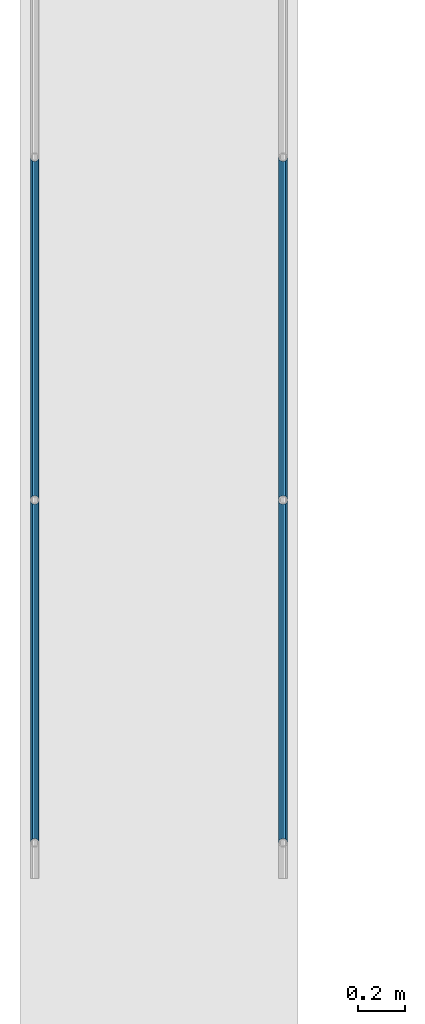
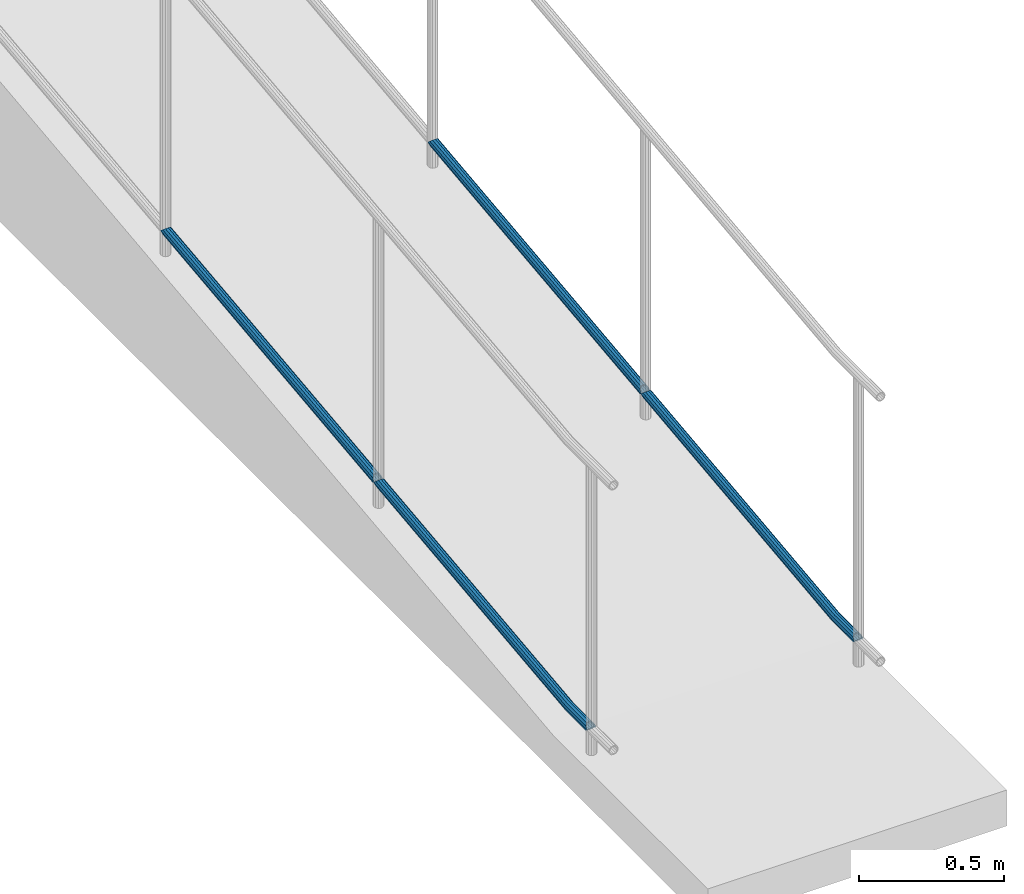
# One storey, part 1031 of 1763: 4 beams, 2 elements without a shape of their own.
"""IFC2X3 building model written with IfcOpenShell, lengths in millimetres."""

from ifc_helpers import new_model, si_unit, frame, origin_with_axes, place, context, subcontext, project, spatial, faceted_brep, material, type_object, element, aggregate, save


model = new_model("IFC2X3")

# Units and contexts
model_context = context("Model", 3, precision=1e-05, world=origin_with_axes())
body_context = subcontext(model_context, "Body", "Model", "MODEL_VIEW")
ifc_project = project(units=[si_unit("LENGTHUNIT", "METRE", prefix="MILLI"), si_unit("AREAUNIT", "SQUARE_METRE"), si_unit("VOLUMEUNIT", "CUBIC_METRE"), si_unit("MASSUNIT", "GRAM", prefix="KILO"), si_unit("TIMEUNIT", "SECOND"), si_unit("PLANEANGLEUNIT", "RADIAN"), si_unit("SOLIDANGLEUNIT", "STERADIAN"), si_unit("THERMODYNAMICTEMPERATUREUNIT", "DEGREE_CELSIUS"), si_unit("LUMINOUSINTENSITYUNIT", "LUMEN")], contexts=[model_context])

# Site, building, storey
site_placement = place(None, origin_with_axes())
site = spatial("IfcSite", under=ifc_project, at=site_placement, CompositionType="ELEMENT")
building_placement = place(site_placement, origin_with_axes())
building = spatial("IfcBuilding", under=site, at=building_placement, Name="Undefined", CompositionType="ELEMENT")
storey_placement = place(building_placement, origin_with_axes())
storey = spatial("IfcBuildingStorey", under=building, at=storey_placement, Name="Undefined", CompositionType="ELEMENT", Elevation=0.0)

# Assembly, beams
assembly_1_placement = place(storey_placement, origin_with_axes())
assembly_1 = element("IfcElementAssembly", 1, at=assembly_1_placement, inside=storey, Name="GUARDRAIL", AssemblyPlace="NOTDEFINED", PredefinedType="RIGID_FRAME")
ifc_material = material(Name="STEEL/A513")
beam_type = type_object("IfcBeamType", PredefinedType="NOTDEFINED")
beam_1_placement = place(assembly_1_placement, frame((-97200.6527017878, -12782.762133617, 3815.58511482554), z_axis=(0.0, -0.114062593029902, 0.993473565260443), x_axis=(0.0, -0.993473565260443, -0.114062593029902)))
beam_1 = element("IfcBeam", 2, at=beam_1_placement, type_object=beam_type, material=ifc_material, Name="GUARDRAIL", context=body_context, shape_type="Brep", body=[
    faceted_brep([(1480.81345318271, 19.0500000000029, 17.3825002176645), (1470.33122847514, 16.4977839420899, 25.7666268186786), (1472.5042094635, 16.4977839420899, 6.84096557126941), (1462.48219982441, -7.68349999999919, 28.6735604524383), (1460.20200757818, 0.0, 30.4840879673138), (1459.78189792043, 0.0, 34.1430491418123), (1462.60858252325, -9.52499999999418, 31.8985935448673), (1463.18246298811, -9.52499999999418, 26.9003596290404), (1463.18246298811, 9.52499999999418, 26.9003596290404), (1462.60858252325, 9.52499999999418, 31.8985935448673), (1462.48219982441, 7.68349999999919, 28.6735604524383), (1467.37252681534, 13.3082123799541, 23.5733481190482), (1470.29431449819, 15.3669999999984, 16.1748205455351), (1469.12539814594, 13.3082123799541, 8.30664804613843), (1465.79841553411, 9.52499999999418, 4.11662061334391), (1466.37229599897, 9.52499999999418, -0.881613302482037), (1465.51826202814, 7.68349999999919, 2.23086026224246), (1463.70775023939, 0.0, -0.0493121785057156), (1464.12785989714, 0.0, -3.70827335300419), (1465.51826202814, -7.68349999999919, 2.23086026224246), (1465.79841553411, -9.52499999999418, 4.11662061334391), (1466.37229599897, -9.52499999999418, -0.881613302482037), (1480.88055896293, -19.0500000000029, 17.39020507842), (1472.5042094635, -16.4977839420899, 6.84096557126941), (1470.33122847514, -16.4977839420899, 25.7666268186786), (1469.12539814594, -13.3082123799541, 8.30664804613843), (1470.29431449818, -15.3669999999984, 16.1748205455351), (1467.37252681534, -13.3082123799541, 23.5733481190482), (1327.81826570677, 9.52499999999418, 16.4977764218675), (1327.81826572123, 0.0, 19.0499924797741), (1328.31826572123, 0.0, 19.049992476942), (1328.46429331386, 9.52499999999418, 16.4977764182086), (1328.81500273226, 0.0, 19.107021784057), (1329.10610495904, 9.52499999999418, 16.5714614318267), (1328.46429331386, -9.52499999999418, 16.4977764182086), (1328.86324811624, -16.4977839420899, 9.5249924738564), (1329.9014110328, -16.4977839420899, 9.64418172387741), (1329.10610495904, -9.52499999999418, 16.5714614318267), (1327.81826570677, -9.52499999999418, 16.4977764218675), (1327.81826566729, -16.4977839420899, 9.52499247977448), (1327.81826561334, -19.0500000000029, -7.52022606320679e-06), (1329.40823051126, -19.0500000000029, -7.52923097024905e-06), (1330.98781933333, -19.0500000000029, 0.181341663697822), (16.9872402594065, 0.0, 19.0499999037911), (14.7112934167653, -9.52499999999418, 16.4977838587747), (8.49329100734212, -16.4977839420899, 9.52499995189828), (-0.000653948576655239, -19.0500000000029, 0.0), (10.6805481559259, -16.4977839420899, -9.52500006049013), (1327.8182655594, -16.4977839420899, -9.5250075202257), (1329.95321290627, -16.4977839420899, -9.52500753231743), (1332.07422763386, -16.4977839420899, -9.28149839648177), (1330.35216770865, -9.52499999999418, -16.4977914766696), (1332.86953370762, -9.52499999999418, -16.208778104432), (1327.81826551992, -9.52499999999418, -16.4977914623196), (1327.81826550547, 0.0, -19.0500075202253), (1330.49819530128, 0.0, -19.0500075354039), (1333.1606359344, 0.0, -18.7443384566614), (1330.35216770865, 9.52499999999418, -16.4977914766696), (1332.86953370762, 9.52499999999418, -16.208778104432), (1327.81826551992, 9.52499999999418, -16.4977914623196), (1327.8182655594, 16.4977839420899, -9.5250075202257), (1329.95321290627, 16.4977839420899, -9.52500753231652), (1332.07422763386, 16.4977839420899, -9.28149839648177), (1329.40823051126, 19.0500000000029, -7.52923097024905e-06), (1330.98781933333, 19.0500000000029, 0.181341663697822), (1327.81826561334, 19.0500000000029, -7.52022606320679e-06), (1327.81826566729, 16.4977839420899, 9.52499247977448), (1328.86324811624, 16.4977839420899, 9.5249924738564), (1329.9014110328, 16.4977839420899, 9.64418172387741), (8.49329100734212, 16.4977839420899, 9.52499995189828), (14.7112934167653, 9.52499999999418, 16.4977838587747), (1327.81826552632, 0.0, -15.3670075202253), (1327.81826553798, 7.68349999999919, -13.308219900181), (18.630188200199, 7.68349999999919, -13.3082124854682), (20.9388848411836, 0.0, -15.3670001185892), (1327.81826556984, 13.3082123799541, -7.68350752022525), (13.6796398687475, 13.3082123799541, -7.6835000774754), (17.9220831536149, 9.52499999999418, -11.4667124814578), (1327.81826561334, 15.3669999999984, -7.52022606320679e-06), (10.7251326051592, 15.3669999999984, -6.07424226473086e-08), (1327.81826565686, 13.3082123799541, 7.68349247977403), (11.9152524355613, 13.3082123799541, 7.68349993251741), (1327.81826570037, 0.0, 15.3669924797741), (1327.81826568871, -7.68349999999919, 13.3082048597298), (15.5741795216873, -7.68349999999919, 13.3082122917494), (17.4101099748004, 0.0, 15.3669999013964), (1327.81826568871, 7.68349999999919, 13.3082048597298), (15.5741795216891, 7.68349999999919, 13.3082122917494), (15.2889441904827, 9.52499999999418, 11.4667122933661), (15.2889441904827, -9.52499999999418, 11.4667122933661), (1327.81826565686, -13.3082123799541, 7.68349247977403), (11.9152524355613, -13.3082123799541, 7.68349993251741), (1327.81826561334, -15.3669999999984, -7.52022606320679e-06), (10.7251326051592, -15.3669999999984, -6.07415131526068e-08), (1327.81826556984, -13.3082123799541, -7.68350752022525), (13.6796398687475, -13.3082123799541, -7.68350007747449), (1327.81826553798, -7.68349999999919, -13.308219900181), (18.6301882001972, -7.68349999999919, -13.3082124854691), (17.9220831536149, -9.52499999999418, -11.4667124814578), (18.4997339273341, -9.52499999999418, -16.4977840468673), (21.3617545565776, 0.0, -19.0500001209839), (18.4997339273341, 9.52499999999418, -16.4977840468673), (10.6805481559259, 16.4977839420899, -9.52500006049013), (-0.000653948576655239, 19.0500000000029, 0.0), (1330.16967318382, -7.68349999999919, -13.3082199134988), (1330.28746877521, 0.0, -15.3670075342097), (1330.16967318382, 7.68349999999919, -13.3082199134988), (1329.84784964324, 13.3082123799541, -7.68350753172035), (1329.40823051126, 15.3669999999984, -7.52923097024905e-06), (1328.96861137928, 13.3082123799541, 7.68349247325932), (1328.64678783869, 7.68349999999919, 13.3082048550368), (1328.5289922473, 0.0, 15.3669924757487), (1328.64678783869, -7.68349999999919, 13.3082048550368), (1328.96861137928, -13.3082123799541, 7.68349247325932), (1329.40823051126, -15.3669999999984, -7.52923097024905e-06), (1329.84784964324, -13.3082123799541, -7.68350753172035), (1331.86418869576, -13.3082123799541, -7.45201598484709), (1332.50573559526, -7.68349999999919, -13.0400216159269), (1332.74055805819, 0.0, -15.085373633392), (1332.50573559526, 7.68349999999919, -13.0400216159269), (1331.86418869576, 13.3082123799541, -7.45201598484709), (1330.98781933333, 15.3669999999984, 0.181341663697822), (1330.1114499709, 13.3082123799541, 7.81469931224274), (1329.4699030714, 7.68349999999919, 13.4027049433216), (1329.23508060847, 0.0, 15.4480569607867), (1329.4699030714, -7.68349999999919, 13.4027049433216), (1330.1114499709, -13.3082123799541, 7.81469931224274), (1330.98781933333, -15.3669999999984, 0.181341663697822)], [[[0, 1, 2]], [[3, 4, 5, 6, 7]], [[8, 9, 5, 4, 10]], [[2, 1, 9, 8, 11, 12, 13, 14, 15]], [[15, 14, 16, 17, 18]], [[18, 17, 19, 20, 21]], [[22, 23, 24]], [[21, 20, 25, 26, 27, 7, 6, 24, 23]], [[28, 29, 30, 31]], [[31, 30, 32, 33]], [[33, 32, 5, 9]], [[34, 35, 36, 37]], [[38, 39, 35, 34]], [[39, 40, 41, 35]], [[35, 41, 42, 36]], [[36, 42, 22, 24]], [[37, 36, 24, 6]], [[32, 37, 6, 5]], [[30, 34, 37, 32]], [[29, 38, 34, 30]], [[38, 29, 43, 44]], [[39, 38, 44, 45]], [[40, 39, 45, 46]], [[46, 45, 47]], [[48, 40, 46, 47]], [[40, 48, 49, 41]], [[41, 49, 50, 42]], [[49, 51, 52, 50]], [[48, 53, 51, 49]], [[53, 54, 55, 51]], [[51, 55, 56, 52]], [[55, 57, 58, 56]], [[54, 59, 57, 55]], [[59, 60, 61, 57]], [[57, 61, 62, 58]], [[61, 63, 64, 62]], [[60, 65, 63, 61]], [[65, 66, 67, 63]], [[63, 67, 68, 64]], [[64, 68, 1, 0]], [[62, 64, 0, 2]], [[58, 62, 2, 15]], [[56, 58, 15, 18]], [[52, 56, 18, 21]], [[50, 52, 21, 23]], [[42, 50, 23, 22]], [[68, 33, 9, 1]], [[67, 31, 33, 68]], [[66, 28, 31, 67]], [[28, 66, 69, 70]], [[29, 28, 70, 43]], [[71, 72, 73, 74]], [[72, 75, 76, 77, 73]], [[75, 78, 79, 76]], [[78, 80, 81, 79]], [[82, 83, 84, 85]], [[86, 82, 85, 87]], [[81, 80, 86, 87, 88]], [[85, 43, 70, 88, 87]], [[84, 89, 44, 43, 85]], [[83, 90, 91, 89, 84]], [[90, 92, 93, 91]], [[92, 94, 95, 93]], [[95, 94, 96, 97, 98]], [[47, 45, 44, 89, 91, 93, 95, 98, 99]], [[53, 48, 47, 99]], [[54, 53, 99, 100]], [[59, 54, 100, 101]], [[60, 59, 101, 102]], [[65, 60, 102, 103]], [[66, 65, 103, 69]], [[102, 69, 103]], [[101, 77, 76, 79, 81, 88, 70, 69, 102]], [[100, 74, 73, 77, 101]], [[99, 98, 97, 74, 100]], [[96, 71, 74, 97]], [[71, 96, 104, 105]], [[72, 71, 105, 106]], [[75, 72, 106, 107]], [[78, 75, 107, 108]], [[80, 78, 108, 109]], [[86, 80, 109, 110]], [[82, 86, 110, 111]], [[83, 82, 111, 112]], [[90, 83, 112, 113]], [[92, 90, 113, 114]], [[94, 92, 114, 115]], [[96, 94, 115, 104]], [[104, 115, 116, 117]], [[105, 104, 117, 118]], [[106, 105, 118, 119]], [[107, 106, 119, 120]], [[108, 107, 120, 121]], [[109, 108, 121, 122]], [[110, 109, 122, 123]], [[111, 110, 123, 124]], [[112, 111, 124, 125]], [[113, 112, 125, 126]], [[114, 113, 126, 127]], [[115, 114, 127, 116]], [[116, 127, 26, 25]], [[19, 117, 116, 25, 20]], [[118, 117, 19, 17]], [[119, 118, 17, 16]], [[120, 119, 16, 14, 13]], [[121, 120, 13, 12]], [[122, 121, 12, 11]], [[10, 123, 122, 11, 8]], [[124, 123, 10, 4]], [[125, 124, 4, 3]], [[126, 125, 3, 7, 27]], [[127, 126, 27, 26]]]),
])
beam_2_placement = place(assembly_1_placement, frame((-97200.6527017878, -12782.762133617, 3815.58511482554), z_axis=(0.0, -0.114062593029902, 0.993473565260443), x_axis=(0.0, 0.993473565260443, 0.114062593029902)))
beam_2 = element("IfcBeam", 3, at=beam_2_placement, type_object=beam_type, material=ifc_material, Name="GUARDRAIL", context=body_context, shape_type="Brep", body=[
    faceted_brep([(1468.16665642951, -9.52499999999418, 16.4977839425555), (1467.58900470802, -9.52499999999418, 11.4667123804174), (1467.30376971339, -7.68349999999919, 13.3082123804179), (1465.46783960526, 0.0, 15.3670000004613), (1465.89071001447, 0.0, 19.0500000004622), (1467.3037697134, 7.68349999999919, 13.308212380417), (1467.58900470802, 9.52499999999418, 11.4667123804174), (1468.16665642951, 9.52499999999418, 16.4977839425555), (1482.87860532686, 19.0500000000029, 4.66570782009512e-10), (1474.38465767071, 16.4977839420899, 9.52500000046439), (1472.19739693342, 16.4977839420899, -9.52499999953761), (1470.96269582906, 13.3082123799541, 7.68350000046303), (1472.15281425492, 15.3669999999984, 4.6293280320242e-10), (1469.19830550098, 13.3082123799541, -7.68349999953807), (1464.95586142462, 9.52499999999418, -11.4667123794952), (1464.37820970313, 9.52499999999418, -16.4977839416342), (1464.24775602078, 7.68349999999919, -13.3082123794957), (1461.9390589491, 0.0, -15.3669999995409), (1461.51618853989, 0.0, -19.0499999995409), (1464.95586142462, -9.52499999999418, -11.4667123794952), (1464.37820970313, -9.52499999999418, -16.4977839416342), (1464.24775602078, -7.68349999999919, -13.3082123794948), (1482.87860532695, -19.0500000000029, 4.55656845588237e-10), (1472.19739693342, -16.4977839420899, -9.52499999953761), (1474.38465767071, -16.4977839420899, 9.52500000046439), (1469.19830550097, -13.3082123799541, -7.68349999953807), (1472.15281425491, -15.3669999999984, 4.6293280320242e-10), (1470.96269582905, -13.3082123799541, 7.68350000046303), (8.49463121237, -16.4977839420899, -9.52499999999782), (14.7126324911599, -9.52499999999418, -16.4977839420899), (0.00068350478454704, 19.0500000000029, 0.0), (8.49463121237, 16.4977839420899, -9.52499999999782), (10.6818918337324, 16.4977839420899, 9.52500000000418), (18.5010790167537, 9.52499999999418, 16.4977839421008), (21.3631001626848, 0.0, 19.0500000000075), (14.7126324911599, 9.52499999999418, -16.4977839420899), (16.9885789199607, 0.0, -19.0499999999956), (17.4114493067575, 0.0, -15.3669999999956), (15.2902841820321, -9.52499999999418, -11.4667123799509), (15.575519187561, -7.68349999999919, -13.3082123799513), (15.575519187561, 7.68349999999919, -13.3082123799513), (15.2902841820321, 9.52499999999418, -11.4667123799509), (11.9165930406441, 13.3082123799541, -7.68349999999646), (10.7264745694495, 15.3669999999984, 4.54747350886464e-12), (13.6809832752053, 13.3082123799541, 7.68350000000555), (17.923427325881, 9.52499999999418, 11.4667123799609), (18.631532718199, 7.68349999999919, 13.3082123799622), (20.9402297758882, 0.0, 15.3670000000075), (18.631532718199, -7.68349999999919, 13.3082123799622), (17.923427325881, -9.52499999999418, 11.4667123799609), (18.5010790167537, -9.52499999999418, 16.4977839421008), (10.6818918337324, -16.4977839420899, 9.52500000000418), (0.00068350478454704, -19.0500000000029, 0.0), (13.6809832752053, -13.3082123799541, 7.68350000000555), (10.7264745694495, -15.3669999999984, 4.54747350886464e-12), (11.9165930406441, -13.3082123799541, -7.68349999999646)], [[[0, 1, 2, 3, 4]], [[4, 3, 5, 6, 7]], [[8, 9, 10]], [[7, 6, 11, 12, 13, 14, 15, 10, 9]], [[16, 17, 18, 15, 14]], [[19, 20, 18, 17, 21]], [[22, 23, 24]], [[24, 23, 20, 19, 25, 26, 27, 1, 0]], [[28, 29, 20, 23]], [[30, 31, 32]], [[33, 34, 4, 7]], [[32, 33, 7, 9]], [[30, 32, 9, 8]], [[31, 30, 8, 10]], [[35, 31, 10, 15]], [[36, 35, 15, 18]], [[29, 36, 18, 20]], [[37, 36, 29, 38, 39]], [[40, 41, 35, 36, 37]], [[32, 31, 35, 41, 42, 43, 44, 45, 33]], [[33, 45, 46, 47, 34]], [[34, 47, 48, 49, 50]], [[34, 50, 0, 4]], [[50, 51, 24, 0]], [[51, 52, 22, 24]], [[52, 28, 23, 22]], [[51, 28, 52]], [[50, 49, 53, 54, 55, 38, 29, 28, 51]], [[55, 54, 26, 25]], [[21, 39, 38, 55, 25, 19]], [[37, 39, 21, 17]], [[40, 37, 17, 16]], [[42, 41, 40, 16, 14, 13]], [[43, 42, 13, 12]], [[44, 43, 12, 11]], [[5, 46, 45, 44, 11, 6]], [[47, 46, 5, 3]], [[48, 47, 3, 2]], [[53, 49, 48, 2, 1, 27]], [[54, 53, 27, 26]]]),
])
aggregate(assembly_1, [beam_1, beam_2])

assembly_2_placement = place(storey_placement, origin_with_axes())
assembly_2 = element("IfcElementAssembly", 4, at=assembly_2_placement, inside=storey, Name="GUARDRAIL", AssemblyPlace="NOTDEFINED", PredefinedType="RIGID_FRAME")
beam_3_placement = place(assembly_2_placement, frame((-96133.8527017878, -12782.762133617, 3815.58511482554), z_axis=(0.0, -0.114062593029902, 0.993473565260443), x_axis=(0.0, -0.993473565260443, -0.114062593029902)))
beam_3 = element("IfcBeam", 5, at=beam_3_placement, type_object=beam_type, material=ifc_material, Name="GUARDRAIL", context=body_context, shape_type="Brep", body=[
    faceted_brep([(1480.81345318271, 19.0500000000029, 17.3825002176645), (1470.33122847514, 16.4977839420899, 25.7666268186786), (1472.5042094635, 16.4977839420899, 6.84096557126941), (1462.48219982441, -7.68349999999919, 28.6735604524383), (1460.20200757818, 0.0, 30.4840879673138), (1459.78189792043, 0.0, 34.1430491418123), (1462.60858252325, -9.52499999999418, 31.8985935448673), (1463.18246298811, -9.52499999999418, 26.9003596290404), (1463.18246298811, 9.52499999999418, 26.9003596290404), (1462.60858252325, 9.52499999999418, 31.8985935448673), (1462.48219982441, 7.68349999999919, 28.6735604524383), (1467.37252681534, 13.3082123799541, 23.5733481190482), (1470.29431449819, 15.3669999999984, 16.1748205455351), (1469.12539814594, 13.3082123799541, 8.30664804613843), (1465.79841553411, 9.52499999999418, 4.11662061334391), (1466.37229599897, 9.52499999999418, -0.881613302482037), (1465.51826202814, 7.68349999999919, 2.23086026224246), (1463.70775023939, 0.0, -0.0493121785057156), (1464.12785989714, 0.0, -3.70827335300419), (1465.51826202814, -7.68349999999919, 2.23086026224246), (1465.79841553411, -9.52499999999418, 4.11662061334391), (1466.37229599897, -9.52499999999418, -0.881613302482037), (1480.88055896293, -19.0500000000029, 17.39020507842), (1472.5042094635, -16.4977839420899, 6.84096557126941), (1470.33122847514, -16.4977839420899, 25.7666268186786), (1469.12539814594, -13.3082123799541, 8.30664804613843), (1470.29431449818, -15.3669999999984, 16.1748205455351), (1467.37252681534, -13.3082123799541, 23.5733481190482), (1327.81826570677, 9.52499999999418, 16.4977764218675), (1327.81826572123, 0.0, 19.0499924797741), (1328.31826572123, 0.0, 19.049992476942), (1328.46429331386, 9.52499999999418, 16.4977764182086), (1328.81500273226, 0.0, 19.107021784057), (1329.10610495904, 9.52499999999418, 16.5714614318267), (1328.46429331386, -9.52499999999418, 16.4977764182086), (1328.86324811624, -16.4977839420899, 9.5249924738564), (1329.9014110328, -16.4977839420899, 9.64418172387741), (1329.10610495904, -9.52499999999418, 16.5714614318267), (1327.81826570677, -9.52499999999418, 16.4977764218675), (1327.81826566729, -16.4977839420899, 9.52499247977448), (1327.81826561334, -19.0500000000029, -7.52022606320679e-06), (1329.40823051126, -19.0500000000029, -7.52923097024905e-06), (1330.98781933333, -19.0500000000029, 0.181341663697822), (16.9872402594065, 0.0, 19.0499999037911), (14.7112934167653, -9.52499999999418, 16.4977838587747), (8.49329100734212, -16.4977839420899, 9.52499995189828), (-0.000653948576655239, -19.0500000000029, 0.0), (10.6805481559259, -16.4977839420899, -9.52500006049013), (1327.8182655594, -16.4977839420899, -9.5250075202257), (1329.95321290627, -16.4977839420899, -9.52500753231743), (1332.07422763386, -16.4977839420899, -9.28149839648177), (1330.35216770865, -9.52499999999418, -16.4977914766696), (1332.86953370762, -9.52499999999418, -16.208778104432), (1327.81826551992, -9.52499999999418, -16.4977914623196), (1327.81826550547, 0.0, -19.0500075202253), (1330.49819530128, 0.0, -19.0500075354039), (1333.1606359344, 0.0, -18.7443384566614), (1330.35216770865, 9.52499999999418, -16.4977914766696), (1332.86953370762, 9.52499999999418, -16.208778104432), (1327.81826551992, 9.52499999999418, -16.4977914623196), (1327.8182655594, 16.4977839420899, -9.5250075202257), (1329.95321290627, 16.4977839420899, -9.52500753231652), (1332.07422763386, 16.4977839420899, -9.28149839648177), (1329.40823051126, 19.0500000000029, -7.52923097024905e-06), (1330.98781933333, 19.0500000000029, 0.181341663697822), (1327.81826561334, 19.0500000000029, -7.52022606320679e-06), (1327.81826566729, 16.4977839420899, 9.52499247977448), (1328.86324811624, 16.4977839420899, 9.5249924738564), (1329.9014110328, 16.4977839420899, 9.64418172387741), (8.49329100734212, 16.4977839420899, 9.52499995189828), (14.7112934167653, 9.52499999999418, 16.4977838587747), (1327.81826552632, 0.0, -15.3670075202253), (1327.81826553798, 7.68349999999919, -13.308219900181), (18.630188200199, 7.68349999999919, -13.3082124854682), (20.9388848411836, 0.0, -15.3670001185892), (1327.81826556984, 13.3082123799541, -7.68350752022525), (13.6796398687475, 13.3082123799541, -7.6835000774754), (17.9220831536149, 9.52499999999418, -11.4667124814578), (1327.81826561334, 15.3669999999984, -7.52022606320679e-06), (10.7251326051592, 15.3669999999984, -6.07424226473086e-08), (1327.81826565686, 13.3082123799541, 7.68349247977403), (11.9152524355613, 13.3082123799541, 7.68349993251741), (1327.81826570037, 0.0, 15.3669924797741), (1327.81826568871, -7.68349999999919, 13.3082048597298), (15.5741795216873, -7.68349999999919, 13.3082122917494), (17.4101099748004, 0.0, 15.3669999013964), (1327.81826568871, 7.68349999999919, 13.3082048597298), (15.5741795216891, 7.68349999999919, 13.3082122917494), (15.2889441904827, 9.52499999999418, 11.4667122933661), (15.2889441904827, -9.52499999999418, 11.4667122933661), (1327.81826565686, -13.3082123799541, 7.68349247977403), (11.9152524355613, -13.3082123799541, 7.68349993251741), (1327.81826561334, -15.3669999999984, -7.52022606320679e-06), (10.7251326051592, -15.3669999999984, -6.07415131526068e-08), (1327.81826556984, -13.3082123799541, -7.68350752022525), (13.6796398687475, -13.3082123799541, -7.68350007747449), (1327.81826553798, -7.68349999999919, -13.308219900181), (18.6301882001972, -7.68349999999919, -13.3082124854691), (17.9220831536149, -9.52499999999418, -11.4667124814578), (18.4997339273341, -9.52499999999418, -16.4977840468673), (21.3617545565776, 0.0, -19.0500001209839), (18.4997339273341, 9.52499999999418, -16.4977840468673), (10.6805481559259, 16.4977839420899, -9.52500006049013), (-0.000653948576655239, 19.0500000000029, 0.0), (1330.16967318382, -7.68349999999919, -13.3082199134988), (1330.28746877521, 0.0, -15.3670075342097), (1330.16967318382, 7.68349999999919, -13.3082199134988), (1329.84784964324, 13.3082123799541, -7.68350753172035), (1329.40823051126, 15.3669999999984, -7.52923097024905e-06), (1328.96861137928, 13.3082123799541, 7.68349247325932), (1328.64678783869, 7.68349999999919, 13.3082048550368), (1328.5289922473, 0.0, 15.3669924757487), (1328.64678783869, -7.68349999999919, 13.3082048550368), (1328.96861137928, -13.3082123799541, 7.68349247325932), (1329.40823051126, -15.3669999999984, -7.52923097024905e-06), (1329.84784964324, -13.3082123799541, -7.68350753172035), (1331.86418869576, -13.3082123799541, -7.45201598484709), (1332.50573559526, -7.68349999999919, -13.0400216159269), (1332.74055805819, 0.0, -15.085373633392), (1332.50573559526, 7.68349999999919, -13.0400216159269), (1331.86418869576, 13.3082123799541, -7.45201598484709), (1330.98781933333, 15.3669999999984, 0.181341663697822), (1330.1114499709, 13.3082123799541, 7.81469931224274), (1329.4699030714, 7.68349999999919, 13.4027049433216), (1329.23508060847, 0.0, 15.4480569607867), (1329.4699030714, -7.68349999999919, 13.4027049433216), (1330.1114499709, -13.3082123799541, 7.81469931224274), (1330.98781933333, -15.3669999999984, 0.181341663697822)], [[[0, 1, 2]], [[3, 4, 5, 6, 7]], [[8, 9, 5, 4, 10]], [[2, 1, 9, 8, 11, 12, 13, 14, 15]], [[15, 14, 16, 17, 18]], [[18, 17, 19, 20, 21]], [[22, 23, 24]], [[21, 20, 25, 26, 27, 7, 6, 24, 23]], [[28, 29, 30, 31]], [[31, 30, 32, 33]], [[33, 32, 5, 9]], [[34, 35, 36, 37]], [[38, 39, 35, 34]], [[39, 40, 41, 35]], [[35, 41, 42, 36]], [[36, 42, 22, 24]], [[37, 36, 24, 6]], [[32, 37, 6, 5]], [[30, 34, 37, 32]], [[29, 38, 34, 30]], [[38, 29, 43, 44]], [[39, 38, 44, 45]], [[40, 39, 45, 46]], [[46, 45, 47]], [[48, 40, 46, 47]], [[40, 48, 49, 41]], [[41, 49, 50, 42]], [[49, 51, 52, 50]], [[48, 53, 51, 49]], [[53, 54, 55, 51]], [[51, 55, 56, 52]], [[55, 57, 58, 56]], [[54, 59, 57, 55]], [[59, 60, 61, 57]], [[57, 61, 62, 58]], [[61, 63, 64, 62]], [[60, 65, 63, 61]], [[65, 66, 67, 63]], [[63, 67, 68, 64]], [[64, 68, 1, 0]], [[62, 64, 0, 2]], [[58, 62, 2, 15]], [[56, 58, 15, 18]], [[52, 56, 18, 21]], [[50, 52, 21, 23]], [[42, 50, 23, 22]], [[68, 33, 9, 1]], [[67, 31, 33, 68]], [[66, 28, 31, 67]], [[28, 66, 69, 70]], [[29, 28, 70, 43]], [[71, 72, 73, 74]], [[72, 75, 76, 77, 73]], [[75, 78, 79, 76]], [[78, 80, 81, 79]], [[82, 83, 84, 85]], [[86, 82, 85, 87]], [[81, 80, 86, 87, 88]], [[85, 43, 70, 88, 87]], [[84, 89, 44, 43, 85]], [[83, 90, 91, 89, 84]], [[90, 92, 93, 91]], [[92, 94, 95, 93]], [[95, 94, 96, 97, 98]], [[47, 45, 44, 89, 91, 93, 95, 98, 99]], [[53, 48, 47, 99]], [[54, 53, 99, 100]], [[59, 54, 100, 101]], [[60, 59, 101, 102]], [[65, 60, 102, 103]], [[66, 65, 103, 69]], [[102, 69, 103]], [[101, 77, 76, 79, 81, 88, 70, 69, 102]], [[100, 74, 73, 77, 101]], [[99, 98, 97, 74, 100]], [[96, 71, 74, 97]], [[71, 96, 104, 105]], [[72, 71, 105, 106]], [[75, 72, 106, 107]], [[78, 75, 107, 108]], [[80, 78, 108, 109]], [[86, 80, 109, 110]], [[82, 86, 110, 111]], [[83, 82, 111, 112]], [[90, 83, 112, 113]], [[92, 90, 113, 114]], [[94, 92, 114, 115]], [[96, 94, 115, 104]], [[104, 115, 116, 117]], [[105, 104, 117, 118]], [[106, 105, 118, 119]], [[107, 106, 119, 120]], [[108, 107, 120, 121]], [[109, 108, 121, 122]], [[110, 109, 122, 123]], [[111, 110, 123, 124]], [[112, 111, 124, 125]], [[113, 112, 125, 126]], [[114, 113, 126, 127]], [[115, 114, 127, 116]], [[116, 127, 26, 25]], [[19, 117, 116, 25, 20]], [[118, 117, 19, 17]], [[119, 118, 17, 16]], [[120, 119, 16, 14, 13]], [[121, 120, 13, 12]], [[122, 121, 12, 11]], [[10, 123, 122, 11, 8]], [[124, 123, 10, 4]], [[125, 124, 4, 3]], [[126, 125, 3, 7, 27]], [[127, 126, 27, 26]]]),
])
beam_4_placement = place(assembly_2_placement, frame((-96133.8527017878, -12782.762133617, 3815.58511482554), z_axis=(0.0, -0.114062593029902, 0.993473565260443), x_axis=(0.0, 0.993473565260443, 0.114062593029902)))
beam_4 = element("IfcBeam", 6, at=beam_4_placement, type_object=beam_type, material=ifc_material, Name="GUARDRAIL", context=body_context, shape_type="Brep", body=[
    faceted_brep([(1468.16665642951, -9.52499999999418, 16.4977839425555), (1467.58900470802, -9.52499999999418, 11.4667123804174), (1467.30376971339, -7.68349999999919, 13.3082123804179), (1465.46783960526, 0.0, 15.3670000004613), (1465.89071001447, 0.0, 19.0500000004622), (1467.3037697134, 7.68349999999919, 13.308212380417), (1467.58900470802, 9.52499999999418, 11.4667123804174), (1468.16665642951, 9.52499999999418, 16.4977839425555), (1482.87860532686, 19.0500000000029, 4.66570782009512e-10), (1474.38465767071, 16.4977839420899, 9.52500000046439), (1472.19739693342, 16.4977839420899, -9.52499999953761), (1470.96269582906, 13.3082123799541, 7.68350000046303), (1472.15281425492, 15.3669999999984, 4.6293280320242e-10), (1469.19830550098, 13.3082123799541, -7.68349999953807), (1464.95586142462, 9.52499999999418, -11.4667123794952), (1464.37820970313, 9.52499999999418, -16.4977839416342), (1464.24775602078, 7.68349999999919, -13.3082123794957), (1461.9390589491, 0.0, -15.3669999995409), (1461.51618853989, 0.0, -19.0499999995409), (1464.95586142462, -9.52499999999418, -11.4667123794952), (1464.37820970313, -9.52499999999418, -16.4977839416342), (1464.24775602078, -7.68349999999919, -13.3082123794948), (1482.87860532695, -19.0500000000029, 4.55656845588237e-10), (1472.19739693342, -16.4977839420899, -9.52499999953761), (1474.38465767071, -16.4977839420899, 9.52500000046439), (1469.19830550097, -13.3082123799541, -7.68349999953807), (1472.15281425491, -15.3669999999984, 4.6293280320242e-10), (1470.96269582905, -13.3082123799541, 7.68350000046303), (8.49463121237, -16.4977839420899, -9.52499999999782), (14.7126324911599, -9.52499999999418, -16.4977839420899), (0.00068350478454704, 19.0500000000029, 0.0), (8.49463121237, 16.4977839420899, -9.52499999999782), (10.6818918337324, 16.4977839420899, 9.52500000000418), (18.5010790167537, 9.52499999999418, 16.4977839421008), (21.3631001626848, 0.0, 19.0500000000075), (14.7126324911599, 9.52499999999418, -16.4977839420899), (16.9885789199607, 0.0, -19.0499999999956), (17.4114493067575, 0.0, -15.3669999999956), (15.2902841820321, -9.52499999999418, -11.4667123799509), (15.575519187561, -7.68349999999919, -13.3082123799513), (15.575519187561, 7.68349999999919, -13.3082123799513), (15.2902841820321, 9.52499999999418, -11.4667123799509), (11.9165930406441, 13.3082123799541, -7.68349999999646), (10.7264745694495, 15.3669999999984, 4.54747350886464e-12), (13.6809832752053, 13.3082123799541, 7.68350000000555), (17.923427325881, 9.52499999999418, 11.4667123799609), (18.631532718199, 7.68349999999919, 13.3082123799622), (20.9402297758882, 0.0, 15.3670000000075), (18.631532718199, -7.68349999999919, 13.3082123799622), (17.923427325881, -9.52499999999418, 11.4667123799609), (18.5010790167537, -9.52499999999418, 16.4977839421008), (10.6818918337324, -16.4977839420899, 9.52500000000418), (0.00068350478454704, -19.0500000000029, 0.0), (13.6809832752053, -13.3082123799541, 7.68350000000555), (10.7264745694495, -15.3669999999984, 4.54747350886464e-12), (11.9165930406441, -13.3082123799541, -7.68349999999646)], [[[0, 1, 2, 3, 4]], [[4, 3, 5, 6, 7]], [[8, 9, 10]], [[7, 6, 11, 12, 13, 14, 15, 10, 9]], [[16, 17, 18, 15, 14]], [[19, 20, 18, 17, 21]], [[22, 23, 24]], [[24, 23, 20, 19, 25, 26, 27, 1, 0]], [[28, 29, 20, 23]], [[30, 31, 32]], [[33, 34, 4, 7]], [[32, 33, 7, 9]], [[30, 32, 9, 8]], [[31, 30, 8, 10]], [[35, 31, 10, 15]], [[36, 35, 15, 18]], [[29, 36, 18, 20]], [[37, 36, 29, 38, 39]], [[40, 41, 35, 36, 37]], [[32, 31, 35, 41, 42, 43, 44, 45, 33]], [[33, 45, 46, 47, 34]], [[34, 47, 48, 49, 50]], [[34, 50, 0, 4]], [[50, 51, 24, 0]], [[51, 52, 22, 24]], [[52, 28, 23, 22]], [[51, 28, 52]], [[50, 49, 53, 54, 55, 38, 29, 28, 51]], [[55, 54, 26, 25]], [[21, 39, 38, 55, 25, 19]], [[37, 39, 21, 17]], [[40, 37, 17, 16]], [[42, 41, 40, 16, 14, 13]], [[43, 42, 13, 12]], [[44, 43, 12, 11]], [[5, 46, 45, 44, 11, 6]], [[47, 46, 5, 3]], [[48, 47, 3, 2]], [[53, 49, 48, 2, 1, 27]], [[54, 53, 27, 26]]]),
])
aggregate(assembly_2, [beam_3, beam_4])

save(model, "model.ifc")
